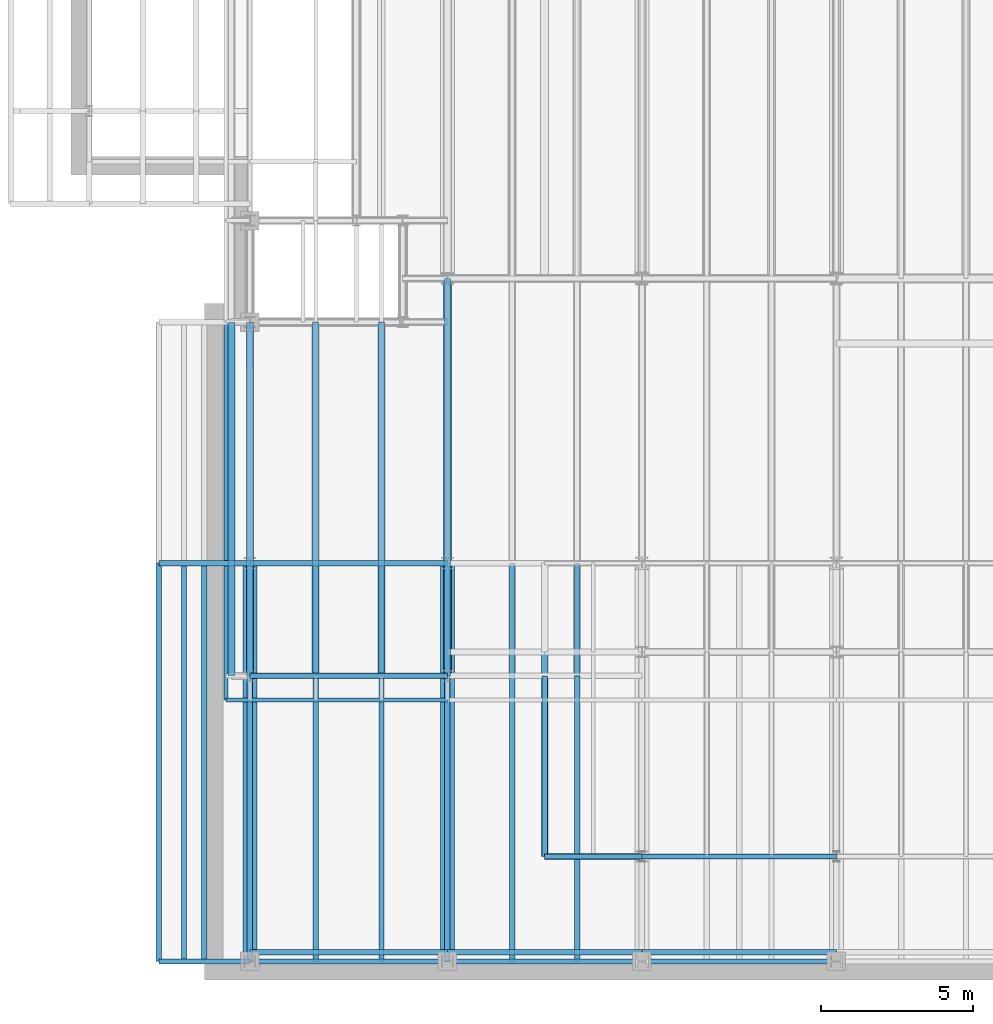
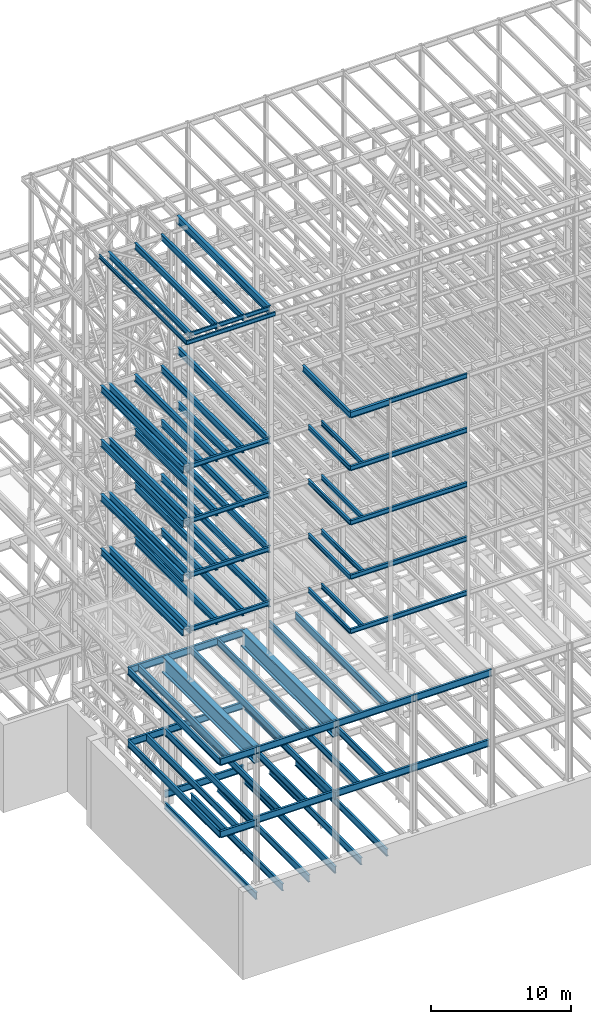
# One storey, part 122 of 150: 84 beams.
"""IFC2X3 building model written with IfcOpenShell, lengths in millimetres."""

from ifc_helpers import new_model, si_unit, frame, origin_with_axes, origin_2d_with_axis, place, context, subcontext, project, spatial, i_section, extrude, material, type_object, element, save


model = new_model("IFC2X3")

# Units and contexts
model_context = context("Model", 3, precision=1e-05, world=origin_with_axes())
body_context = subcontext(model_context, "Body", "Model", "MODEL_VIEW")
ifc_project = project(units=[si_unit("LENGTHUNIT", "METRE", prefix="MILLI"), si_unit("AREAUNIT", "SQUARE_METRE"), si_unit("VOLUMEUNIT", "CUBIC_METRE"), si_unit("MASSUNIT", "GRAM", prefix="KILO"), si_unit("TIMEUNIT", "SECOND"), si_unit("PLANEANGLEUNIT", "RADIAN"), si_unit("SOLIDANGLEUNIT", "STERADIAN"), si_unit("THERMODYNAMICTEMPERATUREUNIT", "DEGREE_CELSIUS"), si_unit("LUMINOUSINTENSITYUNIT", "LUMEN")], contexts=[model_context])

# Site, building, storey
site_placement = place(None, origin_with_axes())
site = spatial("IfcSite", under=ifc_project, at=site_placement, CompositionType="ELEMENT")
building_placement = place(site_placement, origin_with_axes())
building = spatial("IfcBuilding", under=site, at=building_placement, Name="Undefined", CompositionType="ELEMENT")
storey_placement = place(building_placement, origin_with_axes())
storey = spatial("IfcBuildingStorey", under=building, at=storey_placement, Name="Undefined", CompositionType="ELEMENT", Elevation=0.0)

# Beams
ifc_material = material(Name="STEEL/A992")
beam_type_1 = type_object("IfcBeamType", Name="W16X31", PredefinedType="NOTDEFINED")
beam_1_placement = place(storey_placement, frame((18186.4, 3454.4, 59005.7875), z_axis=(0.0, 0.0, 1.0), x_axis=(1.0, 0.0, 0.0)))
element("IfcBeam", 1, at=beam_1_placement, inside=storey, type_object=beam_type_1, material=ifc_material, Name="BEAM", ObjectType="W16X31", context=body_context, shape_type="SweptSolid", body=[
    extrude(i_section(OverallWidth=140.462, OverallDepth=403.225, WebThickness=6.3499, FlangeThickness=11.176, FilletRadius=17.399, at=origin_2d_with_axis()), frame((6400.80000000001, 0.0, 0.0), z_axis=(-1.0, 0.0, 0.0), x_axis=(0.0, -1.0, 0.0)), (0.0, 0.0, 1.0), 6400.8),
])
beam_type_2 = type_object("IfcBeamType", Name="W24X68", PredefinedType="NOTDEFINED")
beam_2_placement = place(storey_placement, frame((11785.6, 9398.0, 54181.375), z_axis=(0.0, 0.0, 1.0), x_axis=(0.0, 1.0, 0.0)))
element("IfcBeam", 2, at=beam_2_placement, inside=storey, type_object=beam_type_2, material=ifc_material, Name="BEAM", ObjectType="W24X68", context=body_context, shape_type="SweptSolid", body=[
    extrude(i_section(OverallWidth=227.838, OverallDepth=603.25, WebThickness=11.1125, FlangeThickness=14.859, FilletRadius=23.2409, at=origin_2d_with_axis()), frame((13081.0, 0.0, 0.0), z_axis=(-1.0, 0.0, 0.0), x_axis=(0.0, -1.0, 0.0)), (0.0, 0.0, 1.0), 13081.0),
])
for number, where, z_axis, x_axis, name in (
    (3, (9618.13333333333, 9398.0, 54181.375), (0.0, 0.0, 1.0), (0.0, 1.0, 0.0), "BEAM"),
    (4, (7450.66666666667, 9398.0, 54181.375), (0.0, 0.0, 1.0), (0.0, 1.0, 0.0), "BEAM"),
    (5, (4673.6, 9398.0, 54181.375), (0.0, 0.0, 1.0), (0.0, 1.0, 0.0), "BEAM"),
    (6, (5283.2, 9398.0, 54181.375), (0.0, 0.0, 1.0), (0.0, 1.0, 0.0), "BEAM"),
):
    element("IfcBeam", number, at=place(storey_placement, frame(where, z_axis=z_axis, x_axis=x_axis)), inside=storey, type_object=beam_type_2, material=ifc_material, Name=name, ObjectType="W24X68", context=body_context, shape_type="SweptSolid", body=[
        extrude(i_section(OverallWidth=227.838, OverallDepth=603.25, WebThickness=11.1125, FlangeThickness=14.859, FilletRadius=23.2409, at=origin_2d_with_axis()), frame((11645.9, 0.0, 0.0), z_axis=(-1.0, 0.0, 0.0), x_axis=(0.0, -1.0, 0.0)), (0.0, 0.0, 1.0), 11645.9),
    ])
beam_3_placement = place(storey_placement, frame((11785.6, 9398.0, 49456.975), z_axis=(0.0, 0.0, 1.0), x_axis=(0.0, 1.0, 0.0)))
element("IfcBeam", 7, at=beam_3_placement, inside=storey, type_object=beam_type_2, material=ifc_material, Name="BEAM", ObjectType="W24X68", context=body_context, shape_type="SweptSolid", body=[
    extrude(i_section(OverallWidth=227.838, OverallDepth=603.25, WebThickness=11.1125, FlangeThickness=14.859, FilletRadius=23.2409, at=origin_2d_with_axis()), frame((13081.0, 0.0, 0.0), z_axis=(-1.0, 0.0, 0.0), x_axis=(0.0, -1.0, 0.0)), (0.0, 0.0, 1.0), 13081.0),
])
for number, where, z_axis, x_axis, name in (
    (8, (9618.13333333333, 9398.0, 49456.975), (0.0, 0.0, 1.0), (0.0, 1.0, 0.0), "BEAM"),
    (9, (7450.66666666667, 9398.0, 49456.975), (0.0, 0.0, 1.0), (0.0, 1.0, 0.0), "BEAM"),
    (10, (4673.6, 9398.0, 49456.975), (0.0, 0.0, 1.0), (0.0, 1.0, 0.0), "BEAM"),
    (11, (5283.2, 9398.0, 49456.975), (0.0, 0.0, 1.0), (0.0, 1.0, 0.0), "BEAM"),
):
    element("IfcBeam", number, at=place(storey_placement, frame(where, z_axis=z_axis, x_axis=x_axis)), inside=storey, type_object=beam_type_2, material=ifc_material, Name=name, ObjectType="W24X68", context=body_context, shape_type="SweptSolid", body=[
        extrude(i_section(OverallWidth=227.838, OverallDepth=603.25, WebThickness=11.1125, FlangeThickness=14.859, FilletRadius=23.2409, at=origin_2d_with_axis()), frame((11645.9, 0.0, 0.0), z_axis=(-1.0, 0.0, 0.0), x_axis=(0.0, -1.0, 0.0)), (0.0, 0.0, 1.0), 11645.9),
    ])
beam_4_placement = place(storey_placement, frame((11785.6, 9398.0, 44732.575), z_axis=(0.0, 0.0, 1.0), x_axis=(0.0, 1.0, 0.0)))
element("IfcBeam", 12, at=beam_4_placement, inside=storey, type_object=beam_type_2, material=ifc_material, Name="BEAM", ObjectType="W24X68", context=body_context, shape_type="SweptSolid", body=[
    extrude(i_section(OverallWidth=227.838, OverallDepth=603.25, WebThickness=11.1125, FlangeThickness=14.859, FilletRadius=23.2409, at=origin_2d_with_axis()), frame((13081.0, 0.0, 0.0), z_axis=(-1.0, 0.0, 0.0), x_axis=(0.0, -1.0, 0.0)), (0.0, 0.0, 1.0), 13081.0),
])
for number, where, z_axis, x_axis, name in (
    (13, (9618.13333333333, 9398.0, 44732.575), (0.0, 0.0, 1.0), (0.0, 1.0, 0.0), "BEAM"),
    (14, (7450.66666666667, 9398.0, 44732.575), (0.0, 0.0, 1.0), (0.0, 1.0, 0.0), "BEAM"),
    (15, (4673.6, 9398.0, 44732.575), (0.0, 0.0, 1.0), (0.0, 1.0, 0.0), "BEAM"),
    (16, (5283.2, 9398.0, 44732.575), (0.0, 0.0, 1.0), (0.0, 1.0, 0.0), "BEAM"),
):
    element("IfcBeam", number, at=place(storey_placement, frame(where, z_axis=z_axis, x_axis=x_axis)), inside=storey, type_object=beam_type_2, material=ifc_material, Name=name, ObjectType="W24X68", context=body_context, shape_type="SweptSolid", body=[
        extrude(i_section(OverallWidth=227.838, OverallDepth=603.25, WebThickness=11.1125, FlangeThickness=14.859, FilletRadius=23.2409, at=origin_2d_with_axis()), frame((11645.9, 0.0, 0.0), z_axis=(-1.0, 0.0, 0.0), x_axis=(0.0, -1.0, 0.0)), (0.0, 0.0, 1.0), 11645.9),
    ])
beam_5_placement = place(storey_placement, frame((11785.6, 9398.0, 40008.175), z_axis=(0.0, 0.0, 1.0), x_axis=(0.0, 1.0, 0.0)))
element("IfcBeam", 17, at=beam_5_placement, inside=storey, type_object=beam_type_2, material=ifc_material, Name="BEAM", ObjectType="W24X68", context=body_context, shape_type="SweptSolid", body=[
    extrude(i_section(OverallWidth=227.838, OverallDepth=603.25, WebThickness=11.1125, FlangeThickness=14.859, FilletRadius=23.2409, at=origin_2d_with_axis()), frame((13081.0, 0.0, 0.0), z_axis=(-1.0, 0.0, 0.0), x_axis=(0.0, -1.0, 0.0)), (0.0, 0.0, 1.0), 13081.0),
])
for number, where, z_axis, x_axis, name in (
    (18, (9618.13333333333, 9398.0, 40008.175), (0.0, 0.0, 1.0), (0.0, 1.0, 0.0), "BEAM"),
    (19, (7450.66666666667, 9398.0, 40008.175), (0.0, 0.0, 1.0), (0.0, 1.0, 0.0), "BEAM"),
    (20, (4673.6, 9398.0, 40008.175), (0.0, 0.0, 1.0), (0.0, 1.0, 0.0), "BEAM"),
    (21, (5283.2, 9398.0, 40008.175), (0.0, 0.0, 1.0), (0.0, 1.0, 0.0), "BEAM"),
):
    element("IfcBeam", number, at=place(storey_placement, frame(where, z_axis=z_axis, x_axis=x_axis)), inside=storey, type_object=beam_type_2, material=ifc_material, Name=name, ObjectType="W24X68", context=body_context, shape_type="SweptSolid", body=[
        extrude(i_section(OverallWidth=227.838, OverallDepth=603.25, WebThickness=11.1125, FlangeThickness=14.859, FilletRadius=23.2409, at=origin_2d_with_axis()), frame((11645.9, 0.0, 0.0), z_axis=(-1.0, 0.0, 0.0), x_axis=(0.0, -1.0, 0.0)), (0.0, 0.0, 1.0), 11645.9),
    ])
beam_type_3 = type_object("IfcBeamType", Name="W14X22", PredefinedType="NOTDEFINED")
beam_6_placement = place(storey_placement, frame((4495.8, 8610.6, 65738.375), z_axis=(0.0, 0.0, 1.0), x_axis=(0.0, 1.0, 0.0)))
element("IfcBeam", 22, at=beam_6_placement, inside=storey, type_object=beam_type_3, material=ifc_material, Name="BEAM", ObjectType="W14X22", context=body_context, shape_type="SweptSolid", body=[
    extrude(i_section(OverallWidth=127.0, OverallDepth=349.25, WebThickness=6.3499, FlangeThickness=8.509, FilletRadius=18.4785, at=origin_2d_with_axis()), frame((12433.3, 0.0, 0.0), z_axis=(-1.0, 0.0, 0.0), x_axis=(0.0, -1.0, 0.0)), (0.0, 0.0, 1.0), 12433.3),
])
beam_7_placement = place(storey_placement, frame((4495.8, 8610.6, 65738.375), z_axis=(0.0, 0.0, 1.0), x_axis=(1.0, 0.0, 0.0)))
element("IfcBeam", 23, at=beam_7_placement, inside=storey, type_object=beam_type_3, material=ifc_material, Name="BEAM", ObjectType="W14X22", context=body_context, shape_type="SweptSolid", body=[
    extrude(i_section(OverallWidth=127.0, OverallDepth=349.25, WebThickness=6.3499, FlangeThickness=8.509, FilletRadius=18.4785, at=origin_2d_with_axis()), frame((7289.8, 0.0, 0.0), z_axis=(-1.0, 0.0, 0.0), x_axis=(0.0, -1.0, 0.0)), (0.0, 0.0, 1.0), 7289.8),
])
beam_8_placement = place(storey_placement, frame((5283.2, 9398.0, 65738.375), z_axis=(0.0, 0.0, 1.0), x_axis=(1.0, 0.0, 0.0)))
element("IfcBeam", 24, at=beam_8_placement, inside=storey, type_object=beam_type_3, material=ifc_material, Name="BEAM", ObjectType="W14X22", context=body_context, shape_type="SweptSolid", body=[
    extrude(i_section(OverallWidth=127.0, OverallDepth=349.25, WebThickness=6.3499, FlangeThickness=8.509, FilletRadius=18.4785, at=origin_2d_with_axis()), frame((6502.4, 0.0, 0.0), z_axis=(-1.0, 0.0, 0.0), x_axis=(0.0, -1.0, 0.0)), (0.0, 0.0, 1.0), 6502.4),
])
beam_type_4 = type_object("IfcBeamType", Name="W21X55", PredefinedType="NOTDEFINED")
for number, where, z_axis, x_axis, name in (
    (25, (5283.2, 9398.0, 65649.475), (0.0, 0.0, 1.0), (0.0, 1.0, 0.0), "BEAM"),
    (26, (9618.13333333333, 9398.0, 65649.475), (0.0, 0.0, 1.0), (0.0, 1.0, 0.0), "BEAM"),
    (27, (7450.66666666667, 9398.0, 65649.475), (0.0, 0.0, 1.0), (0.0, 1.0, 0.0), "BEAM"),
):
    element("IfcBeam", number, at=place(storey_placement, frame(where, z_axis=z_axis, x_axis=x_axis)), inside=storey, type_object=beam_type_4, material=ifc_material, Name=name, ObjectType="W21X55", context=body_context, shape_type="SweptSolid", body=[
        extrude(i_section(OverallWidth=208.788, OverallDepth=527.05, WebThickness=9.5, FlangeThickness=13.2588, FilletRadius=16.8624, at=origin_2d_with_axis()), frame((11645.9, 0.0, 0.0), z_axis=(-1.0, 0.0, 0.0), x_axis=(0.0, -1.0, 0.0)), (0.0, 0.0, 1.0), 11645.9),
    ])
beam_9_placement = place(storey_placement, frame((14986.0, 3454.4, 58943.875), z_axis=(0.0, 0.0, 1.0), x_axis=(1.0, 0.0, 0.0)))
element("IfcBeam", 28, at=beam_9_placement, inside=storey, type_object=beam_type_4, material=ifc_material, Name="BEAM", ObjectType="W21X55", context=body_context, shape_type="SweptSolid", body=[
    extrude(i_section(OverallWidth=208.788, OverallDepth=527.05, WebThickness=9.5, FlangeThickness=13.2588, FilletRadius=16.8624, at=origin_2d_with_axis()), frame((3200.4, 0.0, 0.0), z_axis=(-1.0, 0.0, 0.0), x_axis=(0.0, -1.0, 0.0)), (0.0, 0.0, 1.0), 3200.4),
])
beam_10_placement = place(storey_placement, frame((14986.0, 3454.4, 58943.875), z_axis=(0.0, 0.0, 1.0), x_axis=(0.0, 1.0, 0.0)))
element("IfcBeam", 29, at=beam_10_placement, inside=storey, type_object=beam_type_4, material=ifc_material, Name="BEAM", ObjectType="W21X55", context=body_context, shape_type="SweptSolid", body=[
    extrude(i_section(OverallWidth=208.788, OverallDepth=527.05, WebThickness=9.5, FlangeThickness=13.2588, FilletRadius=16.8624, at=origin_2d_with_axis()), frame((6731.0, 0.0, 0.0), z_axis=(-1.0, 0.0, 0.0), x_axis=(0.0, -1.0, 0.0)), (0.0, 0.0, 1.0), 6731.0),
])
beam_type_5 = type_object("IfcBeamType", Name="W27X84", PredefinedType="NOTDEFINED")
beam_11_placement = place(storey_placement, frame((11785.6, 9398.0, 65573.275), z_axis=(0.0, 0.0, 1.0), x_axis=(0.0, 1.0, 0.0)))
element("IfcBeam", 30, at=beam_11_placement, inside=storey, type_object=beam_type_5, material=ifc_material, Name="BEAM", ObjectType="W27X84", context=body_context, shape_type="SweptSolid", body=[
    extrude(i_section(OverallWidth=254.0, OverallDepth=679.45, WebThickness=11.1125, FlangeThickness=16.256, FilletRadius=23.4314, at=origin_2d_with_axis()), frame((13081.0, 0.0, 0.0), z_axis=(-1.0, 0.0, 0.0), x_axis=(0.0, -1.0, 0.0)), (0.0, 0.0, 1.0), 13081.0),
])
beam_type_6 = type_object("IfcBeamType", Name="W16X36", PredefinedType="NOTDEFINED")
beam_12_placement = place(storey_placement, frame((18186.4, 3454.4, 54281.3875), z_axis=(0.0, 0.0, 1.0), x_axis=(1.0, 0.0, 0.0)))
element("IfcBeam", 31, at=beam_12_placement, inside=storey, type_object=beam_type_6, material=ifc_material, Name="BEAM", ObjectType="W16X36", context=body_context, shape_type="SweptSolid", body=[
    extrude(i_section(OverallWidth=177.8, OverallDepth=403.225, WebThickness=7.9375, FlangeThickness=10.922, FilletRadius=17.6529, at=origin_2d_with_axis()), frame((6400.80000000001, 0.0, 0.0), z_axis=(-1.0, 0.0, 0.0), x_axis=(0.0, -1.0, 0.0)), (0.0, 0.0, 1.0), 6400.8),
])
beam_13_placement = place(storey_placement, frame((14986.0, 3454.4, 54281.3875), z_axis=(0.0, 0.0, 1.0), x_axis=(1.0, 0.0, 0.0)))
element("IfcBeam", 32, at=beam_13_placement, inside=storey, type_object=beam_type_6, material=ifc_material, Name="BEAM", ObjectType="W16X36", context=body_context, shape_type="SweptSolid", body=[
    extrude(i_section(OverallWidth=177.8, OverallDepth=403.225, WebThickness=7.9375, FlangeThickness=10.922, FilletRadius=17.6529, at=origin_2d_with_axis()), frame((3200.4, 0.0, 0.0), z_axis=(-1.0, 0.0, 0.0), x_axis=(0.0, -1.0, 0.0)), (0.0, 0.0, 1.0), 3200.4),
])
for number, where, z_axis, x_axis, name in (
    (33, (14986.0, 3454.4, 54281.3875), (0.0, 0.0, 1.0), (0.0, 1.0, 0.0), "BEAM"),
    (34, (16052.8, 3454.4, 54281.3875), (0.0, 0.0, 1.0), (0.0, 1.0, 0.0), "BEAM"),
):
    element("IfcBeam", number, at=place(storey_placement, frame(where, z_axis=z_axis, x_axis=x_axis)), inside=storey, type_object=beam_type_6, material=ifc_material, Name=name, ObjectType="W16X36", context=body_context, shape_type="SweptSolid", body=[
        extrude(i_section(OverallWidth=177.8, OverallDepth=403.225, WebThickness=7.9375, FlangeThickness=10.922, FilletRadius=17.6529, at=origin_2d_with_axis()), frame((5943.6, 0.0, 0.0), z_axis=(-1.0, 0.0, 0.0), x_axis=(0.0, -1.0, 0.0)), (0.0, 0.0, 1.0), 5943.6),
    ])
beam_14_placement = place(storey_placement, frame((5283.2, 9398.0, 54281.3875), z_axis=(0.0, 0.0, 1.0), x_axis=(1.0, 0.0, 0.0)))
element("IfcBeam", 35, at=beam_14_placement, inside=storey, type_object=beam_type_6, material=ifc_material, Name="BEAM", ObjectType="W16X36", context=body_context, shape_type="SweptSolid", body=[
    extrude(i_section(OverallWidth=177.8, OverallDepth=403.225, WebThickness=7.9375, FlangeThickness=10.922, FilletRadius=17.6529, at=origin_2d_with_axis()), frame((6502.39934976, 0.0, 0.0), z_axis=(-1.0, 0.0, 0.0), x_axis=(0.0, -1.0, 0.0)), (0.0, 0.0, 1.0), 6502.39934976),
])
beam_15_placement = place(storey_placement, frame((18186.4, 3454.4, 49556.9875), z_axis=(0.0, 0.0, 1.0), x_axis=(1.0, 0.0, 0.0)))
element("IfcBeam", 36, at=beam_15_placement, inside=storey, type_object=beam_type_6, material=ifc_material, Name="BEAM", ObjectType="W16X36", context=body_context, shape_type="SweptSolid", body=[
    extrude(i_section(OverallWidth=177.8, OverallDepth=403.225, WebThickness=7.9375, FlangeThickness=10.922, FilletRadius=17.6529, at=origin_2d_with_axis()), frame((6400.80000000001, 0.0, 0.0), z_axis=(-1.0, 0.0, 0.0), x_axis=(0.0, -1.0, 0.0)), (0.0, 0.0, 1.0), 6400.8),
])
beam_16_placement = place(storey_placement, frame((14986.0, 3454.4, 49556.9875), z_axis=(0.0, 0.0, 1.0), x_axis=(1.0, 0.0, 0.0)))
element("IfcBeam", 37, at=beam_16_placement, inside=storey, type_object=beam_type_6, material=ifc_material, Name="BEAM", ObjectType="W16X36", context=body_context, shape_type="SweptSolid", body=[
    extrude(i_section(OverallWidth=177.8, OverallDepth=403.225, WebThickness=7.9375, FlangeThickness=10.922, FilletRadius=17.6529, at=origin_2d_with_axis()), frame((3200.4, 0.0, 0.0), z_axis=(-1.0, 0.0, 0.0), x_axis=(0.0, -1.0, 0.0)), (0.0, 0.0, 1.0), 3200.4),
])
for number, where, z_axis, x_axis, name in (
    (38, (14986.0, 3454.4, 49556.9875), (0.0, 0.0, 1.0), (0.0, 1.0, 0.0), "BEAM"),
    (39, (16052.8, 3454.4, 49556.9875), (0.0, 0.0, 1.0), (0.0, 1.0, 0.0), "BEAM"),
):
    element("IfcBeam", number, at=place(storey_placement, frame(where, z_axis=z_axis, x_axis=x_axis)), inside=storey, type_object=beam_type_6, material=ifc_material, Name=name, ObjectType="W16X36", context=body_context, shape_type="SweptSolid", body=[
        extrude(i_section(OverallWidth=177.8, OverallDepth=403.225, WebThickness=7.9375, FlangeThickness=10.922, FilletRadius=17.6529, at=origin_2d_with_axis()), frame((5943.6, 0.0, 0.0), z_axis=(-1.0, 0.0, 0.0), x_axis=(0.0, -1.0, 0.0)), (0.0, 0.0, 1.0), 5943.6),
    ])
beam_17_placement = place(storey_placement, frame((5283.2, 9398.0, 49556.9875), z_axis=(0.0, 0.0, 1.0), x_axis=(1.0, 0.0, 0.0)))
element("IfcBeam", 40, at=beam_17_placement, inside=storey, type_object=beam_type_6, material=ifc_material, Name="BEAM", ObjectType="W16X36", context=body_context, shape_type="SweptSolid", body=[
    extrude(i_section(OverallWidth=177.8, OverallDepth=403.225, WebThickness=7.9375, FlangeThickness=10.922, FilletRadius=17.6529, at=origin_2d_with_axis()), frame((6502.39934976, 0.0, 0.0), z_axis=(-1.0, 0.0, 0.0), x_axis=(0.0, -1.0, 0.0)), (0.0, 0.0, 1.0), 6502.39934976),
])
beam_18_placement = place(storey_placement, frame((18186.4, 3454.4, 44832.5875), z_axis=(0.0, 0.0, 1.0), x_axis=(1.0, 0.0, 0.0)))
element("IfcBeam", 41, at=beam_18_placement, inside=storey, type_object=beam_type_6, material=ifc_material, Name="BEAM", ObjectType="W16X36", context=body_context, shape_type="SweptSolid", body=[
    extrude(i_section(OverallWidth=177.8, OverallDepth=403.225, WebThickness=7.9375, FlangeThickness=10.922, FilletRadius=17.6529, at=origin_2d_with_axis()), frame((6400.80000000001, 0.0, 0.0), z_axis=(-1.0, 0.0, 0.0), x_axis=(0.0, -1.0, 0.0)), (0.0, 0.0, 1.0), 6400.8),
])
beam_19_placement = place(storey_placement, frame((14986.0, 3454.4, 44832.5875), z_axis=(0.0, 0.0, 1.0), x_axis=(1.0, 0.0, 0.0)))
element("IfcBeam", 42, at=beam_19_placement, inside=storey, type_object=beam_type_6, material=ifc_material, Name="BEAM", ObjectType="W16X36", context=body_context, shape_type="SweptSolid", body=[
    extrude(i_section(OverallWidth=177.8, OverallDepth=403.225, WebThickness=7.9375, FlangeThickness=10.922, FilletRadius=17.6529, at=origin_2d_with_axis()), frame((3200.4, 0.0, 0.0), z_axis=(-1.0, 0.0, 0.0), x_axis=(0.0, -1.0, 0.0)), (0.0, 0.0, 1.0), 3200.4),
])
for number, where, z_axis, x_axis, name in (
    (43, (14986.0, 3454.4, 44832.5875), (0.0, 0.0, 1.0), (0.0, 1.0, 0.0), "BEAM"),
    (44, (16052.8, 3454.4, 44832.5875), (0.0, 0.0, 1.0), (0.0, 1.0, 0.0), "BEAM"),
):
    element("IfcBeam", number, at=place(storey_placement, frame(where, z_axis=z_axis, x_axis=x_axis)), inside=storey, type_object=beam_type_6, material=ifc_material, Name=name, ObjectType="W16X36", context=body_context, shape_type="SweptSolid", body=[
        extrude(i_section(OverallWidth=177.8, OverallDepth=403.225, WebThickness=7.9375, FlangeThickness=10.922, FilletRadius=17.6529, at=origin_2d_with_axis()), frame((5943.6, 0.0, 0.0), z_axis=(-1.0, 0.0, 0.0), x_axis=(0.0, -1.0, 0.0)), (0.0, 0.0, 1.0), 5943.6),
    ])
beam_20_placement = place(storey_placement, frame((5283.2, 9398.0, 44832.5875), z_axis=(0.0, 0.0, 1.0), x_axis=(1.0, 0.0, 0.0)))
element("IfcBeam", 45, at=beam_20_placement, inside=storey, type_object=beam_type_6, material=ifc_material, Name="BEAM", ObjectType="W16X36", context=body_context, shape_type="SweptSolid", body=[
    extrude(i_section(OverallWidth=177.8, OverallDepth=403.225, WebThickness=7.9375, FlangeThickness=10.922, FilletRadius=17.6529, at=origin_2d_with_axis()), frame((6502.39934976, 0.0, 0.0), z_axis=(-1.0, 0.0, 0.0), x_axis=(0.0, -1.0, 0.0)), (0.0, 0.0, 1.0), 6502.39934976),
])
beam_21_placement = place(storey_placement, frame((18186.4, 3454.4, 40108.1875), z_axis=(0.0, 0.0, 1.0), x_axis=(1.0, 0.0, 0.0)))
element("IfcBeam", 46, at=beam_21_placement, inside=storey, type_object=beam_type_6, material=ifc_material, Name="BEAM", ObjectType="W16X36", context=body_context, shape_type="SweptSolid", body=[
    extrude(i_section(OverallWidth=177.8, OverallDepth=403.225, WebThickness=7.9375, FlangeThickness=10.922, FilletRadius=17.6529, at=origin_2d_with_axis()), frame((6400.80000000001, 0.0, 0.0), z_axis=(-1.0, 0.0, 0.0), x_axis=(0.0, -1.0, 0.0)), (0.0, 0.0, 1.0), 6400.8),
])
beam_22_placement = place(storey_placement, frame((14986.0, 3454.4, 40108.1875), z_axis=(0.0, 0.0, 1.0), x_axis=(1.0, 0.0, 0.0)))
element("IfcBeam", 47, at=beam_22_placement, inside=storey, type_object=beam_type_6, material=ifc_material, Name="BEAM", ObjectType="W16X36", context=body_context, shape_type="SweptSolid", body=[
    extrude(i_section(OverallWidth=177.8, OverallDepth=403.225, WebThickness=7.9375, FlangeThickness=10.922, FilletRadius=17.6529, at=origin_2d_with_axis()), frame((3200.4, 0.0, 0.0), z_axis=(-1.0, 0.0, 0.0), x_axis=(0.0, -1.0, 0.0)), (0.0, 0.0, 1.0), 3200.4),
])
for number, where, z_axis, x_axis, name in (
    (48, (14986.0, 3454.4, 40108.1875), (0.0, 0.0, 1.0), (0.0, 1.0, 0.0), "BEAM"),
    (49, (16052.8, 3454.4, 40108.1875), (0.0, 0.0, 1.0), (0.0, 1.0, 0.0), "BEAM"),
):
    element("IfcBeam", number, at=place(storey_placement, frame(where, z_axis=z_axis, x_axis=x_axis)), inside=storey, type_object=beam_type_6, material=ifc_material, Name=name, ObjectType="W16X36", context=body_context, shape_type="SweptSolid", body=[
        extrude(i_section(OverallWidth=177.8, OverallDepth=403.225, WebThickness=7.9375, FlangeThickness=10.922, FilletRadius=17.6529, at=origin_2d_with_axis()), frame((5943.6, 0.0, 0.0), z_axis=(-1.0, 0.0, 0.0), x_axis=(0.0, -1.0, 0.0)), (0.0, 0.0, 1.0), 5943.6),
    ])
beam_23_placement = place(storey_placement, frame((5283.2, 9398.0, 40108.1875), z_axis=(0.0, 0.0, 1.0), x_axis=(1.0, 0.0, 0.0)))
element("IfcBeam", 50, at=beam_23_placement, inside=storey, type_object=beam_type_6, material=ifc_material, Name="BEAM", ObjectType="W16X36", context=body_context, shape_type="SweptSolid", body=[
    extrude(i_section(OverallWidth=177.8, OverallDepth=403.225, WebThickness=7.9375, FlangeThickness=10.922, FilletRadius=17.6529, at=origin_2d_with_axis()), frame((6502.4, 0.0, 0.0), z_axis=(-1.0, 0.0, 0.0), x_axis=(0.0, -1.0, 0.0)), (0.0, 0.0, 1.0), 6502.4),
])
beam_type_7 = type_object("IfcBeamType", Name="W24X62", PredefinedType="NOTDEFINED")
for number, where, z_axis, x_axis, name in (
    (51, (18186.4, 0.0, 35283.775), (0.0, 0.0, 1.0), (1.0, 0.0, 0.0), "BEAM"),
    (52, (11785.6, 0.0, 35283.775), (0.0, 0.0, 1.0), (1.0, 0.0, 0.0), "BEAM"),
):
    element("IfcBeam", number, at=place(storey_placement, frame(where, z_axis=z_axis, x_axis=x_axis)), inside=storey, type_object=beam_type_7, material=ifc_material, Name=name, ObjectType="W24X62", context=body_context, shape_type="SweptSolid", body=[
        extrude(i_section(OverallWidth=177.8, OverallDepth=603.25, WebThickness=11.1125, FlangeThickness=14.986, FilletRadius=23.114, at=origin_2d_with_axis()), frame((6400.80000000001, 0.0, 0.0), z_axis=(-1.0, 0.0, 0.0), x_axis=(0.0, -1.0, 0.0)), (0.0, 0.0, 1.0), 6400.8),
    ])
beam_24_placement = place(storey_placement, frame((5283.2, 0.0, 35283.775), z_axis=(0.0, 0.0, 1.0), x_axis=(1.0, 0.0, 0.0)))
element("IfcBeam", 53, at=beam_24_placement, inside=storey, type_object=beam_type_7, material=ifc_material, Name="BEAM", ObjectType="W24X62", context=body_context, shape_type="SweptSolid", body=[
    extrude(i_section(OverallWidth=177.8, OverallDepth=603.25, WebThickness=11.1125, FlangeThickness=14.986, FilletRadius=23.114, at=origin_2d_with_axis()), frame((6502.4, 0.0, 0.0), z_axis=(-1.0, 0.0, 0.0), x_axis=(0.0, -1.0, 0.0)), (0.0, 0.0, 1.0), 6502.4),
])
for number, where, z_axis, x_axis, name in (
    (54, (3115.73333333333, 0.0, 35283.775), (0.0, 0.0, 1.0), (0.0, 1.0, 0.0), "BEAM"),
    (55, (2286.0, 0.0, 35283.775), (0.0, 0.0, 1.0), (0.0, 1.0, 0.0), "BEAM"),
):
    element("IfcBeam", number, at=place(storey_placement, frame(where, z_axis=z_axis, x_axis=x_axis)), inside=storey, type_object=beam_type_7, material=ifc_material, Name=name, ObjectType="W24X62", context=body_context, shape_type="SweptSolid", body=[
        extrude(i_section(OverallWidth=177.8, OverallDepth=603.25, WebThickness=11.1125, FlangeThickness=14.986, FilletRadius=23.114, at=origin_2d_with_axis()), frame((13106.4, 0.0, 0.0), z_axis=(-1.0, 0.0, 0.0), x_axis=(0.0, -1.0, 0.0)), (0.0, 0.0, 1.0), 13106.4),
    ])
beam_25_placement = place(storey_placement, frame((2286.0, 0.0, 35283.775), z_axis=(0.0, 0.0, 1.0), x_axis=(1.0, 0.0, 0.0)))
element("IfcBeam", 56, at=beam_25_placement, inside=storey, type_object=beam_type_7, material=ifc_material, Name="BEAM", ObjectType="W24X62", context=body_context, shape_type="SweptSolid", body=[
    extrude(i_section(OverallWidth=177.8, OverallDepth=603.25, WebThickness=11.1125, FlangeThickness=14.986, FilletRadius=23.114, at=origin_2d_with_axis()), frame((2997.19995427982, 0.0, 0.0), z_axis=(-1.0, 0.0, 0.0), x_axis=(0.0, -1.0, 0.0)), (0.0, 0.0, 1.0), 2997.2),
])
beam_26_placement = place(storey_placement, frame((5283.2, 13106.4, 35283.775), z_axis=(0.0, 0.0, 1.0), x_axis=(1.0, 0.0, 0.0)))
element("IfcBeam", 57, at=beam_26_placement, inside=storey, type_object=beam_type_7, material=ifc_material, Name="BEAM", ObjectType="W24X62", context=body_context, shape_type="SweptSolid", body=[
    extrude(i_section(OverallWidth=177.8, OverallDepth=603.25, WebThickness=11.1125, FlangeThickness=14.986, FilletRadius=23.114, at=origin_2d_with_axis()), frame((6502.4, 0.0, 0.0), z_axis=(-1.0, 0.0, 0.0), x_axis=(0.0, -1.0, 0.0)), (0.0, 0.0, 1.0), 6502.4),
])
beam_27_placement = place(storey_placement, frame((2286.0, 13106.4, 35283.775), z_axis=(0.0, 0.0, 1.0), x_axis=(1.0, 0.0, 0.0)))
element("IfcBeam", 58, at=beam_27_placement, inside=storey, type_object=beam_type_7, material=ifc_material, Name="BEAM", ObjectType="W24X62", context=body_context, shape_type="SweptSolid", body=[
    extrude(i_section(OverallWidth=177.8, OverallDepth=603.25, WebThickness=11.1125, FlangeThickness=14.986, FilletRadius=23.114, at=origin_2d_with_axis()), frame((2997.19995427982, 0.0, 0.0), z_axis=(-1.0, 0.0, 0.0), x_axis=(0.0, -1.0, 0.0)), (0.0, 0.0, 1.0), 2997.2),
])
for number, where, z_axis, x_axis, name in (
    (59, (16052.8, 0.0, 35283.775), (0.0, 0.0, 1.0), (0.0, 1.0, 0.0), "BEAM"),
    (60, (13919.2, 0.0, 35283.775), (0.0, 0.0, 1.0), (0.0, 1.0, 0.0), "BEAM"),
    (61, (9618.13333333333, 0.0, 35283.775), (0.0, 0.0, 1.0), (0.0, 1.0, 0.0), "BEAM"),
    (62, (7450.66666666666, 0.0, 35283.775), (0.0, 0.0, 1.0), (0.0, 1.0, 0.0), "BEAM"),
):
    element("IfcBeam", number, at=place(storey_placement, frame(where, z_axis=z_axis, x_axis=x_axis)), inside=storey, type_object=beam_type_7, material=ifc_material, Name=name, ObjectType="W24X62", context=body_context, shape_type="SweptSolid", body=[
        extrude(i_section(OverallWidth=177.8, OverallDepth=603.25, WebThickness=11.1125, FlangeThickness=14.986, FilletRadius=23.114, at=origin_2d_with_axis()), frame((13106.4, 0.0, 0.0), z_axis=(-1.0, 0.0, 0.0), x_axis=(0.0, -1.0, 0.0)), (0.0, 0.0, 1.0), 13106.4),
    ])
for number, where, z_axis, x_axis, name in (
    (63, (16052.8, 304.8, 28984.575), (0.0, 0.0, 1.0), (0.0, 1.0, 0.0), "BEAM"),
    (64, (13919.2, 304.8, 28984.575), (0.0, 0.0, 1.0), (0.0, 1.0, 0.0), "BEAM"),
):
    element("IfcBeam", number, at=place(storey_placement, frame(where, z_axis=z_axis, x_axis=x_axis)), inside=storey, type_object=beam_type_7, material=ifc_material, Name=name, ObjectType="W24X62", context=body_context, shape_type="SweptSolid", body=[
        extrude(i_section(OverallWidth=177.8, OverallDepth=603.25, WebThickness=11.1125, FlangeThickness=14.986, FilletRadius=23.114, at=origin_2d_with_axis()), frame((12801.6, 0.0, 0.0), z_axis=(-1.0, 0.0, 0.0), x_axis=(0.0, -1.0, 0.0)), (0.0, 0.0, 1.0), 12801.6),
    ])
beam_28_placement = place(storey_placement, frame((11785.6, 0.0, 28984.575), z_axis=(0.0, 0.0, 1.0), x_axis=(0.0, 1.0, 0.0)))
element("IfcBeam", 65, at=beam_28_placement, inside=storey, type_object=beam_type_7, material=ifc_material, Name="BEAM", ObjectType="W24X62", context=body_context, shape_type="SweptSolid", body=[
    extrude(i_section(OverallWidth=177.8, OverallDepth=603.25, WebThickness=11.1125, FlangeThickness=14.986, FilletRadius=23.114, at=origin_2d_with_axis()), frame((13106.4, 0.0, 0.0), z_axis=(-1.0, 0.0, 0.0), x_axis=(0.0, -1.0, 0.0)), (0.0, 0.0, 1.0), 13106.4),
])
for number, where, z_axis, x_axis, name in (
    (66, (9618.13289984, 304.8, 28984.575), (0.0, 0.0, 1.0), (0.0, 1.0, 0.0), "BEAM"),
    (67, (7450.66644992, 304.8, 28984.575), (0.0, 0.0, 1.0), (0.0, 1.0, 0.0), "BEAM"),
):
    element("IfcBeam", number, at=place(storey_placement, frame(where, z_axis=z_axis, x_axis=x_axis)), inside=storey, type_object=beam_type_7, material=ifc_material, Name=name, ObjectType="W24X62", context=body_context, shape_type="SweptSolid", body=[
        extrude(i_section(OverallWidth=177.8, OverallDepth=603.25, WebThickness=11.1125, FlangeThickness=14.986, FilletRadius=23.114, at=origin_2d_with_axis()), frame((12801.6, 0.0, 0.0), z_axis=(-1.0, 0.0, 0.0), x_axis=(0.0, -1.0, 0.0)), (0.0, 0.0, 1.0), 12801.6),
    ])
for number, where, z_axis, x_axis, name in (
    (68, (18186.4, 304.8, 28984.575), (0.0, 0.0, 1.0), (1.0, 0.0, 0.0), "BEAM"),
    (69, (11785.6, 304.8, 28984.575), (0.0, 0.0, 1.0), (1.0, 0.0, 0.0), "BEAM"),
):
    element("IfcBeam", number, at=place(storey_placement, frame(where, z_axis=z_axis, x_axis=x_axis)), inside=storey, type_object=beam_type_7, material=ifc_material, Name=name, ObjectType="W24X62", context=body_context, shape_type="SweptSolid", body=[
        extrude(i_section(OverallWidth=177.8, OverallDepth=603.25, WebThickness=11.1125, FlangeThickness=14.986, FilletRadius=23.114, at=origin_2d_with_axis()), frame((6400.80000000001, 0.0, 0.0), z_axis=(-1.0, 0.0, 0.0), x_axis=(0.0, -1.0, 0.0)), (0.0, 0.0, 1.0), 6400.8),
    ])
beam_29_placement = place(storey_placement, frame((5283.2, 304.8, 28984.575), z_axis=(0.0, 0.0, 1.0), x_axis=(1.0, 0.0, 0.0)))
element("IfcBeam", 70, at=beam_29_placement, inside=storey, type_object=beam_type_7, material=ifc_material, Name="BEAM", ObjectType="W24X62", context=body_context, shape_type="SweptSolid", body=[
    extrude(i_section(OverallWidth=177.8, OverallDepth=603.25, WebThickness=11.1125, FlangeThickness=14.986, FilletRadius=23.114, at=origin_2d_with_axis()), frame((6502.39934976, 0.0, 0.0), z_axis=(-1.0, 0.0, 0.0), x_axis=(0.0, -1.0, 0.0)), (0.0, 0.0, 1.0), 6502.39934976),
])
for number, where, z_axis, x_axis, name in (
    (71, (5283.2, 0.0, 28984.575), (0.0, 0.0, 1.0), (0.0, 1.0, 0.0), "BEAM"),
    (72, (3784.6, 0.0, 28984.575), (0.0, 0.0, 1.0), (0.0, 1.0, 0.0), "BEAM"),
    (73, (2286.0, 0.0, 28984.575), (0.0, 0.0, 1.0), (0.0, 1.0, 0.0), "BEAM"),
):
    element("IfcBeam", number, at=place(storey_placement, frame(where, z_axis=z_axis, x_axis=x_axis)), inside=storey, type_object=beam_type_7, material=ifc_material, Name=name, ObjectType="W24X62", context=body_context, shape_type="SweptSolid", body=[
        extrude(i_section(OverallWidth=177.8, OverallDepth=603.25, WebThickness=11.1125, FlangeThickness=14.986, FilletRadius=23.114, at=origin_2d_with_axis()), frame((13106.4, 0.0, 0.0), z_axis=(-1.0, 0.0, 0.0), x_axis=(0.0, -1.0, 0.0)), (0.0, 0.0, 1.0), 13106.4),
    ])
beam_30_placement = place(storey_placement, frame((2286.0, 13106.4, 28984.575), z_axis=(0.0, 0.0, 1.0), x_axis=(1.0, 0.0, 0.0)))
element("IfcBeam", 74, at=beam_30_placement, inside=storey, type_object=beam_type_7, material=ifc_material, Name="BEAM", ObjectType="W24X62", context=body_context, shape_type="SweptSolid", body=[
    extrude(i_section(OverallWidth=177.8, OverallDepth=603.25, WebThickness=11.1125, FlangeThickness=14.986, FilletRadius=23.114, at=origin_2d_with_axis()), frame((9499.6, 0.0, 0.0), z_axis=(-1.0, 0.0, 0.0), x_axis=(0.0, -1.0, 0.0)), (0.0, 0.0, 1.0), 9499.6),
])
beam_31_placement = place(storey_placement, frame((2286.0, 0.0, 28984.575), z_axis=(0.0, 0.0, 1.0), x_axis=(1.0, 0.0, 0.0)))
element("IfcBeam", 75, at=beam_31_placement, inside=storey, type_object=beam_type_7, material=ifc_material, Name="BEAM", ObjectType="W24X62", context=body_context, shape_type="SweptSolid", body=[
    extrude(i_section(OverallWidth=177.8, OverallDepth=603.25, WebThickness=11.1125, FlangeThickness=14.986, FilletRadius=23.114, at=origin_2d_with_axis()), frame((2997.19995427982, 0.0, 0.0), z_axis=(-1.0, 0.0, 0.0), x_axis=(0.0, -1.0, 0.0)), (0.0, 0.0, 1.0), 2997.2),
])
beam_32_placement = place(storey_placement, frame((5283.2, 13106.4, 23472.775), z_axis=(0.0, 0.0, 1.0), x_axis=(1.0, 0.0, 0.0)))
element("IfcBeam", 76, at=beam_32_placement, inside=storey, type_object=beam_type_7, material=ifc_material, Name="BEAM", ObjectType="W24X62", context=body_context, shape_type="SweptSolid", body=[
    extrude(i_section(OverallWidth=177.8, OverallDepth=603.25, WebThickness=11.1125, FlangeThickness=14.986, FilletRadius=23.114, at=origin_2d_with_axis()), frame((6502.4, 0.0, 0.0), z_axis=(-1.0, 0.0, 0.0), x_axis=(0.0, -1.0, 0.0)), (0.0, 0.0, 1.0), 6502.4),
])
for number, where, z_axis, x_axis, name in (
    (77, (16052.8, 0.0, 22558.375), (0.0, 0.0, 1.0), (0.0, 1.0, 0.0), "BEAM"),
    (78, (13919.2, 0.0, 22558.375), (0.0, 0.0, 1.0), (0.0, 1.0, 0.0), "BEAM"),
    (79, (9618.13333333333, 0.0, 22558.375), (0.0, 0.0, 1.0), (0.0, 1.0, 0.0), "BEAM"),
    (80, (7450.66666666667, 0.0, 22558.375), (0.0, 0.0, 1.0), (0.0, 1.0, 0.0), "BEAM"),
    (81, (11785.6, 0.0, 22558.375), (0.0, 0.0, 1.0), (0.0, 1.0, 0.0), "BEAM"),
    (82, (5283.2, 0.0, 22558.375), (0.0, 0.0, 1.0), (0.0, 1.0, 0.0), "BEAM"),
):
    element("IfcBeam", number, at=place(storey_placement, frame(where, z_axis=z_axis, x_axis=x_axis)), inside=storey, type_object=beam_type_7, material=ifc_material, Name=name, ObjectType="W24X62", context=body_context, shape_type="SweptSolid", body=[
        extrude(i_section(OverallWidth=177.8, OverallDepth=603.25, WebThickness=11.1125, FlangeThickness=14.986, FilletRadius=23.114, at=origin_2d_with_axis()), frame((13106.4, 0.0, 0.0), z_axis=(-1.0, 0.0, 0.0), x_axis=(0.0, -1.0, 0.0)), (0.0, 0.0, 1.0), 13106.4),
    ])
beam_type_8 = type_object("IfcBeamType", PredefinedType="NOTDEFINED")
for number, where, z_axis, x_axis, name in (
    (83, (5283.2, 0.0, 34861.5), (0.0, 0.0, 1.0), (0.0, 1.0, 0.0), "BEAM"),
    (84, (11785.6, 0.0, 34861.5), (0.0, 0.0, 1.0), (0.0, 1.0, 0.0), "BEAM"),
):
    element("IfcBeam", number, at=place(storey_placement, frame(where, z_axis=z_axis, x_axis=x_axis)), inside=storey, type_object=beam_type_8, material=ifc_material, Name=name, context=body_context, shape_type="SweptSolid", body=[
        extrude(i_section(OverallWidth=457.2, OverallDepth=1447.8, WebThickness=44.45, FlangeThickness=88.9, FilletRadius=31.115, at=origin_2d_with_axis()), frame((13106.4, 0.0, 0.0), z_axis=(-1.0, 0.0, 0.0), x_axis=(0.0, -1.0, 0.0)), (0.0, 0.0, 1.0), 13106.4),
    ])

save(model, "model.ifc")
